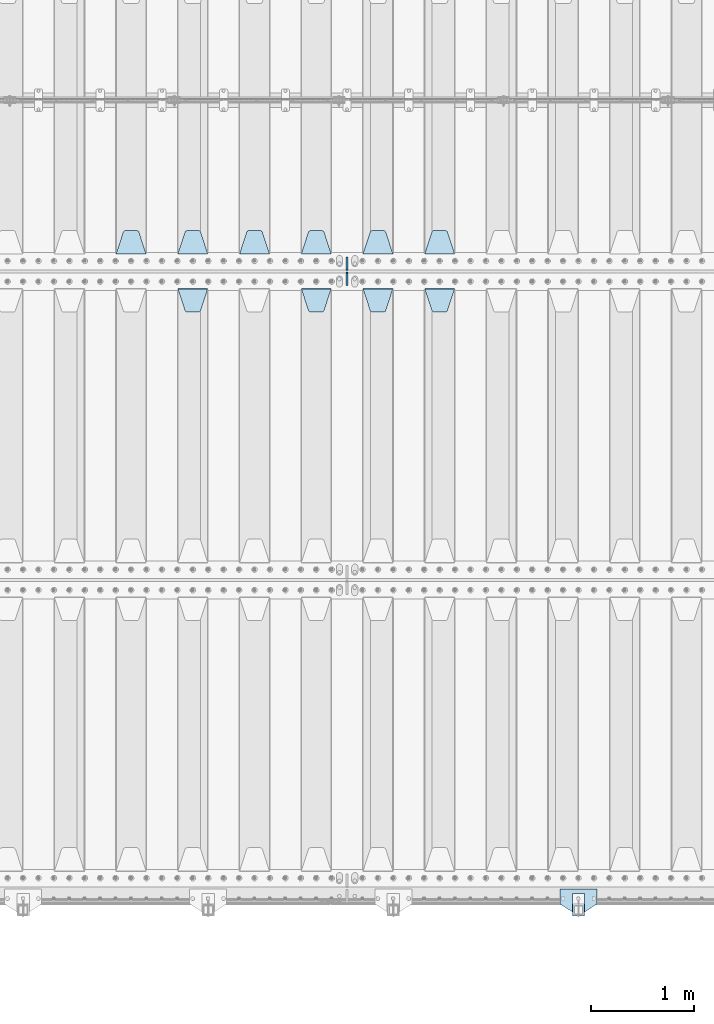
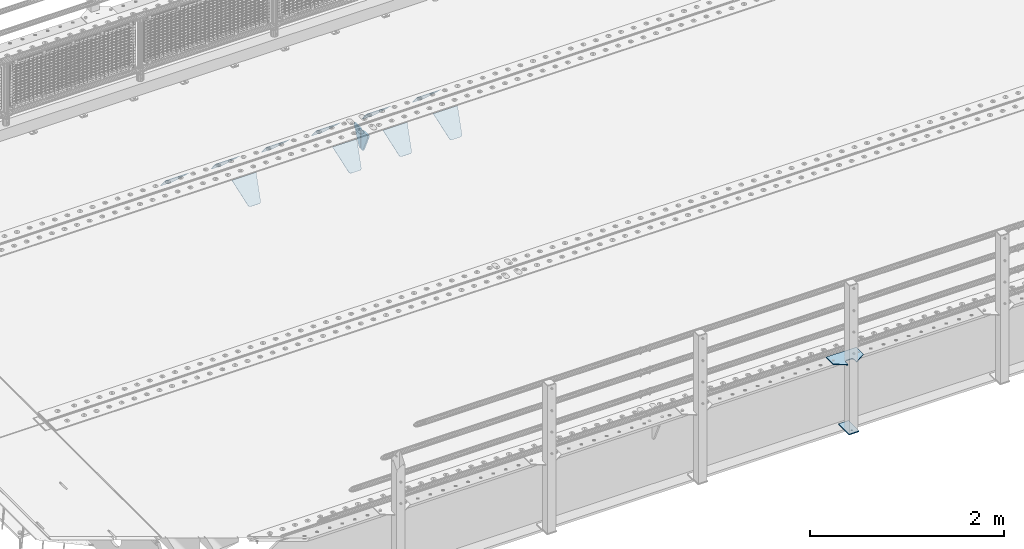
# One storey, part 202 of 247: 14 plates.
"""IFC2X3 building model written with IfcOpenShell, lengths in millimetres."""

from ifc_helpers import new_model, si_unit, frame, origin_with_axes, place, context, subcontext, project, spatial, faceted_brep, material, type_object, element, save


model = new_model("IFC2X3")

# Units and contexts
model_context = context("Model", 3, precision=1e-05, world=origin_with_axes())
body_context = subcontext(model_context, "Body", "Model", "MODEL_VIEW")
ifc_project = project(units=[si_unit("LENGTHUNIT", "METRE", prefix="MILLI"), si_unit("AREAUNIT", "SQUARE_METRE"), si_unit("VOLUMEUNIT", "CUBIC_METRE"), si_unit("MASSUNIT", "GRAM", prefix="KILO"), si_unit("TIMEUNIT", "SECOND"), si_unit("PLANEANGLEUNIT", "RADIAN"), si_unit("SOLIDANGLEUNIT", "STERADIAN"), si_unit("THERMODYNAMICTEMPERATUREUNIT", "DEGREE_CELSIUS"), si_unit("LUMINOUSINTENSITYUNIT", "LUMEN")], contexts=[model_context])

# Site, building, storey
site_placement = place(None, origin_with_axes())
site = spatial("IfcSite", under=ifc_project, at=site_placement, CompositionType="ELEMENT")
building_placement = place(site_placement, origin_with_axes())
building = spatial("IfcBuilding", under=site, at=building_placement, Name="Standard", CompositionType="ELEMENT")
storey_placement = place(building_placement, origin_with_axes())
storey = spatial("IfcBuildingStorey", under=building, at=storey_placement, Name="Undefined", CompositionType="ELEMENT", Elevation=0.0)

# Plates
ifc_material_1 = material(Name="STEEL/S355N")
plate_type_1 = type_object("IfcPlateType", PredefinedType="NOTDEFINED")
plate_1_placement = place(storey_placement, frame((6255.0, 5831.76776695594, -1.767766952965), z_axis=(0.0, -0.707106781186548, -0.707106781186547), x_axis=(1.0, 0.0, 0.0)))
element("IfcPlate", 1, at=plate_1_placement, inside=storey, type_object=plate_type_1, material=ifc_material_1, context=body_context, shape_type="Brep", body=[
    faceted_brep([(0.0, -2.49999999999909, 0.0), (69.345504679477, -2.5, 300.17173142483), (69.345504679477, 2.50000000000091, 300.171731424831), (0.0, 2.5, -9.09494701772928e-13), (70.9274061199576, -2.5, 304.897442415399), (70.9274061199576, 2.50000000000091, 304.8974424154), (73.3818627772307, -2.49999999999909, 309.234538108527), (73.3818627772307, 2.5, 309.234538108526), (76.6187032999551, -2.5, 313.023683126102), (76.6187032999551, 2.50000000000091, 313.023683126102), (80.5190132704993, -2.49999999999909, 316.125672595371), (80.5190132704993, 2.50000000000091, 316.125672595372), (84.9395038596849, -2.49999999999909, 318.426546230476), (84.9395038596849, 2.5, 318.426546230475), (89.7177759439219, -2.5, 319.841774983274), (89.7177759439219, 2.50000000000091, 319.841774983275), (94.678286292652, -2.5, 320.319366455077), (94.678286292652, 2.50000000000091, 320.319366455077), (195.321713707348, -2.5, 320.319366455077), (195.321713707348, 2.50000000000091, 320.319366455077), (200.282224056078, -2.5, 319.841774983274), (200.282224056078, 2.50000000000091, 319.841774983275), (205.060496140315, -2.5, 318.426546230475), (205.060496140315, 2.5, 318.426546230474), (209.480986729501, -2.49999999999818, 316.12567259537), (209.480986729501, 2.50000000000091, 316.12567259537), (213.381296700045, -2.5, 313.023683126101), (213.381296700045, 2.50000000000091, 313.023683126101), (216.618137222769, -2.5, 309.234538108525), (216.618137222769, 2.5, 309.234538108525), (219.072593880042, -2.49999999999909, 304.897442415398), (219.072593880042, 2.5, 304.897442415398), (220.654495320523, -2.5, 300.17173142483), (220.654495320523, 2.50000000000091, 300.171731424831), (290.0, -2.49999999999909, 0.0), (290.0, 2.5, -9.09494701772928e-13)], [[[0, 1, 2, 3]], [[1, 4, 5, 2]], [[4, 6, 7, 5]], [[6, 8, 9, 7]], [[8, 10, 11, 9]], [[10, 12, 13, 11]], [[12, 14, 15, 13]], [[14, 16, 17, 15]], [[16, 18, 19, 17]], [[18, 20, 21, 19]], [[20, 22, 23, 21]], [[22, 24, 25, 23]], [[24, 26, 27, 25]], [[26, 28, 29, 27]], [[28, 30, 31, 29]], [[30, 32, 33, 31]], [[32, 34, 35, 33]], [[34, 0, 3, 35]], [[5, 7, 9, 11, 13, 15, 17, 19, 21, 23, 25, 27, 29, 31, 33, 35, 3, 2]], [[34, 32, 30, 28, 26, 24, 22, 20, 18, 16, 14, 12, 10, 8, 6, 4, 1, 0]]]),
])
plate_2_placement = place(storey_placement, frame((5655.0, 5831.76776695594, -1.767766952965), z_axis=(0.0, -0.707106781186548, -0.707106781186547), x_axis=(1.0, 0.0, 0.0)))
element("IfcPlate", 2, at=plate_2_placement, inside=storey, type_object=plate_type_1, material=ifc_material_1, context=body_context, shape_type="Brep", body=[
    faceted_brep([(0.0, -2.49999999999909, 0.0), (69.345504679477, -2.5, 300.17173142483), (69.345504679477, 2.50000000000091, 300.171731424831), (0.0, 2.5, -9.09494701772928e-13), (70.9274061199576, -2.5, 304.897442415399), (70.9274061199576, 2.50000000000091, 304.8974424154), (73.3818627772307, -2.49999999999909, 309.234538108527), (73.3818627772307, 2.5, 309.234538108526), (76.6187032999551, -2.5, 313.023683126102), (76.6187032999551, 2.50000000000091, 313.023683126102), (80.5190132704993, -2.49999999999909, 316.125672595371), (80.5190132704993, 2.50000000000091, 316.125672595372), (84.9395038596849, -2.49999999999909, 318.426546230476), (84.9395038596849, 2.5, 318.426546230475), (89.7177759439219, -2.5, 319.841774983274), (89.7177759439219, 2.50000000000091, 319.841774983275), (94.678286292652, -2.5, 320.319366455077), (94.678286292652, 2.50000000000091, 320.319366455077), (195.321713707348, -2.5, 320.319366455077), (195.321713707348, 2.50000000000091, 320.319366455077), (200.282224056078, -2.5, 319.841774983274), (200.282224056078, 2.50000000000091, 319.841774983275), (205.060496140315, -2.5, 318.426546230475), (205.060496140315, 2.5, 318.426546230474), (209.480986729501, -2.49999999999818, 316.12567259537), (209.480986729501, 2.50000000000091, 316.12567259537), (213.381296700045, -2.5, 313.023683126101), (213.381296700045, 2.50000000000091, 313.023683126101), (216.618137222769, -2.5, 309.234538108525), (216.618137222769, 2.5, 309.234538108525), (219.072593880042, -2.49999999999909, 304.897442415398), (219.072593880042, 2.5, 304.897442415398), (220.654495320523, -2.5, 300.17173142483), (220.654495320523, 2.50000000000091, 300.171731424831), (290.0, -2.49999999999909, 0.0), (290.0, 2.5, -9.09494701772928e-13)], [[[0, 1, 2, 3]], [[1, 4, 5, 2]], [[4, 6, 7, 5]], [[6, 8, 9, 7]], [[8, 10, 11, 9]], [[10, 12, 13, 11]], [[12, 14, 15, 13]], [[14, 16, 17, 15]], [[16, 18, 19, 17]], [[18, 20, 21, 19]], [[20, 22, 23, 21]], [[22, 24, 25, 23]], [[24, 26, 27, 25]], [[26, 28, 29, 27]], [[28, 30, 31, 29]], [[30, 32, 33, 31]], [[32, 34, 35, 33]], [[34, 0, 3, 35]], [[5, 7, 9, 11, 13, 15, 17, 19, 21, 23, 25, 27, 29, 31, 33, 35, 3, 2]], [[34, 32, 30, 28, 26, 24, 22, 20, 18, 16, 14, 12, 10, 8, 6, 4, 1, 0]]]),
])
plate_3_placement = place(storey_placement, frame((5055.0, 5831.76776695594, -1.767766952965), z_axis=(0.0, -0.707106781186548, -0.707106781186547), x_axis=(1.0, 0.0, 0.0)))
element("IfcPlate", 3, at=plate_3_placement, inside=storey, type_object=plate_type_1, material=ifc_material_1, context=body_context, shape_type="Brep", body=[
    faceted_brep([(0.0, -2.49999999999909, 0.0), (69.345504679477, -2.5, 300.17173142483), (69.345504679477, 2.50000000000091, 300.171731424831), (0.0, 2.5, -9.09494701772928e-13), (70.9274061199576, -2.5, 304.897442415399), (70.9274061199576, 2.50000000000091, 304.8974424154), (73.3818627772307, -2.49999999999909, 309.234538108527), (73.3818627772307, 2.5, 309.234538108526), (76.6187032999551, -2.5, 313.023683126102), (76.6187032999551, 2.50000000000091, 313.023683126102), (80.5190132704993, -2.49999999999909, 316.125672595371), (80.5190132704993, 2.50000000000091, 316.125672595372), (84.9395038596849, -2.49999999999909, 318.426546230476), (84.9395038596849, 2.5, 318.426546230475), (89.7177759439219, -2.5, 319.841774983274), (89.7177759439219, 2.50000000000091, 319.841774983275), (94.678286292652, -2.5, 320.319366455077), (94.678286292652, 2.50000000000091, 320.319366455077), (195.321713707348, -2.5, 320.319366455077), (195.321713707348, 2.50000000000091, 320.319366455077), (200.282224056078, -2.5, 319.841774983274), (200.282224056078, 2.50000000000091, 319.841774983275), (205.060496140315, -2.5, 318.426546230475), (205.060496140315, 2.5, 318.426546230474), (209.480986729501, -2.49999999999818, 316.12567259537), (209.480986729501, 2.50000000000091, 316.12567259537), (213.381296700045, -2.5, 313.023683126101), (213.381296700045, 2.50000000000091, 313.023683126101), (216.618137222769, -2.5, 309.234538108525), (216.618137222769, 2.5, 309.234538108525), (219.072593880042, -2.49999999999909, 304.897442415398), (219.072593880042, 2.5, 304.897442415398), (220.654495320523, -2.5, 300.17173142483), (220.654495320523, 2.50000000000091, 300.171731424831), (290.0, -2.49999999999909, 0.0), (290.0, 2.5, -9.09494701772928e-13)], [[[0, 1, 2, 3]], [[1, 4, 5, 2]], [[4, 6, 7, 5]], [[6, 8, 9, 7]], [[8, 10, 11, 9]], [[10, 12, 13, 11]], [[12, 14, 15, 13]], [[14, 16, 17, 15]], [[16, 18, 19, 17]], [[18, 20, 21, 19]], [[20, 22, 23, 21]], [[22, 24, 25, 23]], [[24, 26, 27, 25]], [[26, 28, 29, 27]], [[28, 30, 31, 29]], [[30, 32, 33, 31]], [[32, 34, 35, 33]], [[34, 0, 3, 35]], [[5, 7, 9, 11, 13, 15, 17, 19, 21, 23, 25, 27, 29, 31, 33, 35, 3, 2]], [[34, 32, 30, 28, 26, 24, 22, 20, 18, 16, 14, 12, 10, 8, 6, 4, 1, 0]]]),
])
plate_4_placement = place(storey_placement, frame((3855.0, 5831.76776695594, -1.767766952965), z_axis=(0.0, -0.707106781186548, -0.707106781186547), x_axis=(1.0, 0.0, 0.0)))
element("IfcPlate", 4, at=plate_4_placement, inside=storey, type_object=plate_type_1, material=ifc_material_1, context=body_context, shape_type="Brep", body=[
    faceted_brep([(0.0, -2.49999999999909, 0.0), (69.345504679477, -2.5, 300.17173142483), (69.345504679477, 2.50000000000091, 300.171731424831), (0.0, 2.5, -9.09494701772928e-13), (70.9274061199576, -2.5, 304.897442415399), (70.9274061199576, 2.50000000000091, 304.8974424154), (73.3818627772307, -2.49999999999909, 309.234538108527), (73.3818627772307, 2.5, 309.234538108526), (76.6187032999551, -2.5, 313.023683126102), (76.6187032999551, 2.50000000000091, 313.023683126102), (80.5190132704993, -2.49999999999909, 316.125672595371), (80.5190132704993, 2.50000000000091, 316.125672595372), (84.9395038596849, -2.49999999999909, 318.426546230476), (84.9395038596849, 2.5, 318.426546230475), (89.7177759439219, -2.5, 319.841774983274), (89.7177759439219, 2.50000000000091, 319.841774983275), (94.678286292652, -2.5, 320.319366455077), (94.678286292652, 2.50000000000091, 320.319366455077), (195.321713707348, -2.5, 320.319366455077), (195.321713707348, 2.50000000000091, 320.319366455077), (200.282224056078, -2.5, 319.841774983274), (200.282224056078, 2.50000000000091, 319.841774983275), (205.060496140315, -2.5, 318.426546230475), (205.060496140315, 2.5, 318.426546230474), (209.480986729501, -2.49999999999818, 316.12567259537), (209.480986729501, 2.50000000000091, 316.12567259537), (213.381296700045, -2.5, 313.023683126101), (213.381296700045, 2.50000000000091, 313.023683126101), (216.618137222769, -2.5, 309.234538108525), (216.618137222769, 2.5, 309.234538108525), (219.072593880042, -2.49999999999909, 304.897442415398), (219.072593880042, 2.5, 304.897442415398), (220.654495320523, -2.5, 300.17173142483), (220.654495320523, 2.50000000000091, 300.171731424831), (290.0, -2.49999999999909, 0.0), (290.0, 2.5, -9.09494701772928e-13)], [[[0, 1, 2, 3]], [[1, 4, 5, 2]], [[4, 6, 7, 5]], [[6, 8, 9, 7]], [[8, 10, 11, 9]], [[10, 12, 13, 11]], [[12, 14, 15, 13]], [[14, 16, 17, 15]], [[16, 18, 19, 17]], [[18, 20, 21, 19]], [[20, 22, 23, 21]], [[22, 24, 25, 23]], [[24, 26, 27, 25]], [[26, 28, 29, 27]], [[28, 30, 31, 29]], [[30, 32, 33, 31]], [[32, 34, 35, 33]], [[34, 0, 3, 35]], [[5, 7, 9, 11, 13, 15, 17, 19, 21, 23, 25, 27, 29, 31, 33, 35, 3, 2]], [[34, 32, 30, 28, 26, 24, 22, 20, 18, 16, 14, 12, 10, 8, 6, 4, 1, 0]]]),
])
plate_5_placement = place(storey_placement, frame((6545.0, 6168.23223304703, -1.76776695296758), z_axis=(0.0, 0.707106781186548, -0.707106781186547), x_axis=(-1.0, 0.0, 0.0)))
element("IfcPlate", 5, at=plate_5_placement, inside=storey, type_object=plate_type_1, material=ifc_material_1, context=body_context, shape_type="Brep", body=[
    faceted_brep([(0.0, -2.49999999999909, 0.0), (69.345504679477, -2.5, 300.17173142483), (69.345504679477, 2.50000000000091, 300.171731424831), (0.0, 2.5, -9.09494701772928e-13), (70.9274061199576, -2.5, 304.897442415399), (70.9274061199576, 2.50000000000091, 304.8974424154), (73.3818627772307, -2.49999999999909, 309.234538108527), (73.3818627772307, 2.5, 309.234538108526), (76.6187032999551, -2.5, 313.023683126102), (76.6187032999551, 2.50000000000091, 313.023683126102), (80.5190132704993, -2.49999999999909, 316.125672595371), (80.5190132704993, 2.50000000000091, 316.125672595372), (84.9395038596849, -2.49999999999909, 318.426546230476), (84.9395038596849, 2.5, 318.426546230475), (89.7177759439219, -2.5, 319.841774983274), (89.7177759439219, 2.50000000000091, 319.841774983275), (94.678286292652, -2.5, 320.319366455077), (94.678286292652, 2.50000000000091, 320.319366455077), (195.321713707348, -2.5, 320.319366455077), (195.321713707348, 2.50000000000091, 320.319366455077), (200.282224056078, -2.5, 319.841774983274), (200.282224056078, 2.50000000000091, 319.841774983275), (205.060496140315, -2.5, 318.426546230475), (205.060496140315, 2.5, 318.426546230474), (209.480986729501, -2.49999999999818, 316.12567259537), (209.480986729501, 2.50000000000091, 316.12567259537), (213.381296700045, -2.5, 313.023683126101), (213.381296700045, 2.50000000000091, 313.023683126101), (216.618137222769, -2.5, 309.234538108525), (216.618137222769, 2.5, 309.234538108525), (219.072593880042, -2.49999999999909, 304.897442415398), (219.072593880042, 2.5, 304.897442415398), (220.654495320523, -2.5, 300.17173142483), (220.654495320523, 2.50000000000091, 300.171731424831), (290.0, -2.49999999999909, 0.0), (290.0, 2.5, -9.09494701772928e-13)], [[[0, 1, 2, 3]], [[1, 4, 5, 2]], [[4, 6, 7, 5]], [[6, 8, 9, 7]], [[8, 10, 11, 9]], [[10, 12, 13, 11]], [[12, 14, 15, 13]], [[14, 16, 17, 15]], [[16, 18, 19, 17]], [[18, 20, 21, 19]], [[20, 22, 23, 21]], [[22, 24, 25, 23]], [[24, 26, 27, 25]], [[26, 28, 29, 27]], [[28, 30, 31, 29]], [[30, 32, 33, 31]], [[32, 34, 35, 33]], [[34, 0, 3, 35]], [[5, 7, 9, 11, 13, 15, 17, 19, 21, 23, 25, 27, 29, 31, 33, 35, 3, 2]], [[34, 32, 30, 28, 26, 24, 22, 20, 18, 16, 14, 12, 10, 8, 6, 4, 1, 0]]]),
])
plate_6_placement = place(storey_placement, frame((5945.0, 6168.23223304703, -1.76776695296758), z_axis=(0.0, 0.707106781186548, -0.707106781186547), x_axis=(-1.0, 0.0, 0.0)))
element("IfcPlate", 6, at=plate_6_placement, inside=storey, type_object=plate_type_1, material=ifc_material_1, context=body_context, shape_type="Brep", body=[
    faceted_brep([(0.0, -2.49999999999909, 0.0), (69.345504679477, -2.5, 300.17173142483), (69.345504679477, 2.50000000000091, 300.171731424831), (0.0, 2.5, -9.09494701772928e-13), (70.9274061199576, -2.5, 304.897442415399), (70.9274061199576, 2.50000000000091, 304.8974424154), (73.3818627772307, -2.49999999999909, 309.234538108527), (73.3818627772307, 2.5, 309.234538108526), (76.6187032999551, -2.5, 313.023683126102), (76.6187032999551, 2.50000000000091, 313.023683126102), (80.5190132704993, -2.49999999999909, 316.125672595371), (80.5190132704993, 2.50000000000091, 316.125672595372), (84.9395038596849, -2.49999999999909, 318.426546230476), (84.9395038596849, 2.5, 318.426546230475), (89.7177759439219, -2.5, 319.841774983274), (89.7177759439219, 2.50000000000091, 319.841774983275), (94.678286292652, -2.5, 320.319366455077), (94.678286292652, 2.50000000000091, 320.319366455077), (195.321713707348, -2.5, 320.319366455077), (195.321713707348, 2.50000000000091, 320.319366455077), (200.282224056078, -2.5, 319.841774983274), (200.282224056078, 2.50000000000091, 319.841774983275), (205.060496140315, -2.5, 318.426546230475), (205.060496140315, 2.5, 318.426546230474), (209.480986729501, -2.49999999999818, 316.12567259537), (209.480986729501, 2.50000000000091, 316.12567259537), (213.381296700045, -2.5, 313.023683126101), (213.381296700045, 2.50000000000091, 313.023683126101), (216.618137222769, -2.5, 309.234538108525), (216.618137222769, 2.5, 309.234538108525), (219.072593880042, -2.49999999999909, 304.897442415398), (219.072593880042, 2.5, 304.897442415398), (220.654495320523, -2.5, 300.17173142483), (220.654495320523, 2.50000000000091, 300.171731424831), (290.0, -2.49999999999909, 0.0), (290.0, 2.5, -9.09494701772928e-13)], [[[0, 1, 2, 3]], [[1, 4, 5, 2]], [[4, 6, 7, 5]], [[6, 8, 9, 7]], [[8, 10, 11, 9]], [[10, 12, 13, 11]], [[12, 14, 15, 13]], [[14, 16, 17, 15]], [[16, 18, 19, 17]], [[18, 20, 21, 19]], [[20, 22, 23, 21]], [[22, 24, 25, 23]], [[24, 26, 27, 25]], [[26, 28, 29, 27]], [[28, 30, 31, 29]], [[30, 32, 33, 31]], [[32, 34, 35, 33]], [[34, 0, 3, 35]], [[5, 7, 9, 11, 13, 15, 17, 19, 21, 23, 25, 27, 29, 31, 33, 35, 3, 2]], [[34, 32, 30, 28, 26, 24, 22, 20, 18, 16, 14, 12, 10, 8, 6, 4, 1, 0]]]),
])
plate_7_placement = place(storey_placement, frame((5345.0, 6168.23223304703, -1.76776695296758), z_axis=(0.0, 0.707106781186548, -0.707106781186547), x_axis=(-1.0, 0.0, 0.0)))
element("IfcPlate", 7, at=plate_7_placement, inside=storey, type_object=plate_type_1, material=ifc_material_1, context=body_context, shape_type="Brep", body=[
    faceted_brep([(0.0, -2.49999999999909, 0.0), (69.345504679477, -2.5, 300.17173142483), (69.345504679477, 2.50000000000091, 300.171731424831), (0.0, 2.5, -9.09494701772928e-13), (70.9274061199576, -2.5, 304.897442415399), (70.9274061199576, 2.50000000000091, 304.8974424154), (73.3818627772307, -2.49999999999909, 309.234538108527), (73.3818627772307, 2.5, 309.234538108526), (76.6187032999551, -2.5, 313.023683126102), (76.6187032999551, 2.50000000000091, 313.023683126102), (80.5190132704993, -2.49999999999909, 316.125672595371), (80.5190132704993, 2.50000000000091, 316.125672595372), (84.9395038596849, -2.49999999999909, 318.426546230476), (84.9395038596849, 2.5, 318.426546230475), (89.7177759439219, -2.5, 319.841774983274), (89.7177759439219, 2.50000000000091, 319.841774983275), (94.678286292652, -2.5, 320.319366455077), (94.678286292652, 2.50000000000091, 320.319366455077), (195.321713707348, -2.5, 320.319366455077), (195.321713707348, 2.50000000000091, 320.319366455077), (200.282224056078, -2.5, 319.841774983274), (200.282224056078, 2.50000000000091, 319.841774983275), (205.060496140315, -2.5, 318.426546230475), (205.060496140315, 2.5, 318.426546230474), (209.480986729501, -2.49999999999818, 316.12567259537), (209.480986729501, 2.50000000000091, 316.12567259537), (213.381296700045, -2.5, 313.023683126101), (213.381296700045, 2.50000000000091, 313.023683126101), (216.618137222769, -2.5, 309.234538108525), (216.618137222769, 2.5, 309.234538108525), (219.072593880042, -2.49999999999909, 304.897442415398), (219.072593880042, 2.5, 304.897442415398), (220.654495320523, -2.5, 300.17173142483), (220.654495320523, 2.50000000000091, 300.171731424831), (290.0, -2.49999999999909, 0.0), (290.0, 2.5, -9.09494701772928e-13)], [[[0, 1, 2, 3]], [[1, 4, 5, 2]], [[4, 6, 7, 5]], [[6, 8, 9, 7]], [[8, 10, 11, 9]], [[10, 12, 13, 11]], [[12, 14, 15, 13]], [[14, 16, 17, 15]], [[16, 18, 19, 17]], [[18, 20, 21, 19]], [[20, 22, 23, 21]], [[22, 24, 25, 23]], [[24, 26, 27, 25]], [[26, 28, 29, 27]], [[28, 30, 31, 29]], [[30, 32, 33, 31]], [[32, 34, 35, 33]], [[34, 0, 3, 35]], [[5, 7, 9, 11, 13, 15, 17, 19, 21, 23, 25, 27, 29, 31, 33, 35, 3, 2]], [[34, 32, 30, 28, 26, 24, 22, 20, 18, 16, 14, 12, 10, 8, 6, 4, 1, 0]]]),
])
plate_8_placement = place(storey_placement, frame((4745.0, 6168.23223304703, -1.76776695296758), z_axis=(0.0, 0.707106781186548, -0.707106781186547), x_axis=(-1.0, 0.0, 0.0)))
element("IfcPlate", 8, at=plate_8_placement, inside=storey, type_object=plate_type_1, material=ifc_material_1, context=body_context, shape_type="Brep", body=[
    faceted_brep([(0.0, -2.49999999999909, 0.0), (69.345504679477, -2.5, 300.17173142483), (69.345504679477, 2.50000000000091, 300.171731424831), (0.0, 2.5, -9.09494701772928e-13), (70.9274061199576, -2.5, 304.897442415399), (70.9274061199576, 2.50000000000091, 304.8974424154), (73.3818627772307, -2.49999999999909, 309.234538108527), (73.3818627772307, 2.5, 309.234538108526), (76.6187032999551, -2.5, 313.023683126102), (76.6187032999551, 2.50000000000091, 313.023683126102), (80.5190132704993, -2.49999999999909, 316.125672595371), (80.5190132704993, 2.50000000000091, 316.125672595372), (84.9395038596849, -2.49999999999909, 318.426546230476), (84.9395038596849, 2.5, 318.426546230475), (89.7177759439219, -2.5, 319.841774983274), (89.7177759439219, 2.50000000000091, 319.841774983275), (94.678286292652, -2.5, 320.319366455077), (94.678286292652, 2.50000000000091, 320.319366455077), (195.321713707348, -2.5, 320.319366455077), (195.321713707348, 2.50000000000091, 320.319366455077), (200.282224056078, -2.5, 319.841774983274), (200.282224056078, 2.50000000000091, 319.841774983275), (205.060496140315, -2.5, 318.426546230475), (205.060496140315, 2.5, 318.426546230474), (209.480986729501, -2.49999999999818, 316.12567259537), (209.480986729501, 2.50000000000091, 316.12567259537), (213.381296700045, -2.5, 313.023683126101), (213.381296700045, 2.50000000000091, 313.023683126101), (216.618137222769, -2.5, 309.234538108525), (216.618137222769, 2.5, 309.234538108525), (219.072593880042, -2.49999999999909, 304.897442415398), (219.072593880042, 2.5, 304.897442415398), (220.654495320523, -2.5, 300.17173142483), (220.654495320523, 2.50000000000091, 300.171731424831), (290.0, -2.49999999999909, 0.0), (290.0, 2.5, -9.09494701772928e-13)], [[[0, 1, 2, 3]], [[1, 4, 5, 2]], [[4, 6, 7, 5]], [[6, 8, 9, 7]], [[8, 10, 11, 9]], [[10, 12, 13, 11]], [[12, 14, 15, 13]], [[14, 16, 17, 15]], [[16, 18, 19, 17]], [[18, 20, 21, 19]], [[20, 22, 23, 21]], [[22, 24, 25, 23]], [[24, 26, 27, 25]], [[26, 28, 29, 27]], [[28, 30, 31, 29]], [[30, 32, 33, 31]], [[32, 34, 35, 33]], [[34, 0, 3, 35]], [[5, 7, 9, 11, 13, 15, 17, 19, 21, 23, 25, 27, 29, 31, 33, 35, 3, 2]], [[34, 32, 30, 28, 26, 24, 22, 20, 18, 16, 14, 12, 10, 8, 6, 4, 1, 0]]]),
])
plate_9_placement = place(storey_placement, frame((4145.0, 6168.23223304703, -1.76776695296758), z_axis=(0.0, 0.707106781186548, -0.707106781186547), x_axis=(-1.0, 0.0, 0.0)))
element("IfcPlate", 9, at=plate_9_placement, inside=storey, type_object=plate_type_1, material=ifc_material_1, context=body_context, shape_type="Brep", body=[
    faceted_brep([(0.0, -2.49999999999909, 0.0), (69.345504679477, -2.5, 300.17173142483), (69.345504679477, 2.50000000000091, 300.171731424831), (0.0, 2.5, -9.09494701772928e-13), (70.9274061199576, -2.5, 304.897442415399), (70.9274061199576, 2.50000000000091, 304.8974424154), (73.3818627772307, -2.49999999999909, 309.234538108527), (73.3818627772307, 2.5, 309.234538108526), (76.6187032999551, -2.5, 313.023683126102), (76.6187032999551, 2.50000000000091, 313.023683126102), (80.5190132704993, -2.49999999999909, 316.125672595371), (80.5190132704993, 2.50000000000091, 316.125672595372), (84.9395038596849, -2.49999999999909, 318.426546230476), (84.9395038596849, 2.5, 318.426546230475), (89.7177759439219, -2.5, 319.841774983274), (89.7177759439219, 2.50000000000091, 319.841774983275), (94.678286292652, -2.5, 320.319366455077), (94.678286292652, 2.50000000000091, 320.319366455077), (195.321713707348, -2.5, 320.319366455077), (195.321713707348, 2.50000000000091, 320.319366455077), (200.282224056078, -2.5, 319.841774983274), (200.282224056078, 2.50000000000091, 319.841774983275), (205.060496140315, -2.5, 318.426546230475), (205.060496140315, 2.5, 318.426546230474), (209.480986729501, -2.49999999999818, 316.12567259537), (209.480986729501, 2.50000000000091, 316.12567259537), (213.381296700045, -2.5, 313.023683126101), (213.381296700045, 2.50000000000091, 313.023683126101), (216.618137222769, -2.5, 309.234538108525), (216.618137222769, 2.5, 309.234538108525), (219.072593880042, -2.49999999999909, 304.897442415398), (219.072593880042, 2.5, 304.897442415398), (220.654495320523, -2.5, 300.17173142483), (220.654495320523, 2.50000000000091, 300.171731424831), (290.0, -2.49999999999909, 0.0), (290.0, 2.5, -9.09494701772928e-13)], [[[0, 1, 2, 3]], [[1, 4, 5, 2]], [[4, 6, 7, 5]], [[6, 8, 9, 7]], [[8, 10, 11, 9]], [[10, 12, 13, 11]], [[12, 14, 15, 13]], [[14, 16, 17, 15]], [[16, 18, 19, 17]], [[18, 20, 21, 19]], [[20, 22, 23, 21]], [[22, 24, 25, 23]], [[24, 26, 27, 25]], [[26, 28, 29, 27]], [[28, 30, 31, 29]], [[30, 32, 33, 31]], [[32, 34, 35, 33]], [[34, 0, 3, 35]], [[5, 7, 9, 11, 13, 15, 17, 19, 21, 23, 25, 27, 29, 31, 33, 35, 3, 2]], [[34, 32, 30, 28, 26, 24, 22, 20, 18, 16, 14, 12, 10, 8, 6, 4, 1, 0]]]),
])
plate_10_placement = place(storey_placement, frame((3545.0, 6168.23223304703, -1.76776695296758), z_axis=(0.0, 0.707106781186548, -0.707106781186547), x_axis=(-1.0, 0.0, 0.0)))
element("IfcPlate", 10, at=plate_10_placement, inside=storey, type_object=plate_type_1, material=ifc_material_1, context=body_context, shape_type="Brep", body=[
    faceted_brep([(0.0, -2.49999999999909, 0.0), (69.345504679477, -2.5, 300.17173142483), (69.345504679477, 2.50000000000091, 300.171731424831), (0.0, 2.5, -9.09494701772928e-13), (70.9274061199576, -2.5, 304.897442415399), (70.9274061199576, 2.50000000000091, 304.8974424154), (73.3818627772307, -2.49999999999909, 309.234538108527), (73.3818627772307, 2.5, 309.234538108526), (76.6187032999551, -2.5, 313.023683126102), (76.6187032999551, 2.50000000000091, 313.023683126102), (80.5190132704993, -2.49999999999909, 316.125672595371), (80.5190132704993, 2.50000000000091, 316.125672595372), (84.9395038596849, -2.49999999999909, 318.426546230476), (84.9395038596849, 2.5, 318.426546230475), (89.7177759439219, -2.5, 319.841774983274), (89.7177759439219, 2.50000000000091, 319.841774983275), (94.678286292652, -2.5, 320.319366455077), (94.678286292652, 2.50000000000091, 320.319366455077), (195.321713707348, -2.5, 320.319366455077), (195.321713707348, 2.50000000000091, 320.319366455077), (200.282224056078, -2.5, 319.841774983274), (200.282224056078, 2.50000000000091, 319.841774983275), (205.060496140315, -2.5, 318.426546230475), (205.060496140315, 2.5, 318.426546230474), (209.480986729501, -2.49999999999818, 316.12567259537), (209.480986729501, 2.50000000000091, 316.12567259537), (213.381296700045, -2.5, 313.023683126101), (213.381296700045, 2.50000000000091, 313.023683126101), (216.618137222769, -2.5, 309.234538108525), (216.618137222769, 2.5, 309.234538108525), (219.072593880042, -2.49999999999909, 304.897442415398), (219.072593880042, 2.5, 304.897442415398), (220.654495320523, -2.5, 300.17173142483), (220.654495320523, 2.50000000000091, 300.171731424831), (290.0, -2.49999999999909, 0.0), (290.0, 2.5, -9.09494701772928e-13)], [[[0, 1, 2, 3]], [[1, 4, 5, 2]], [[4, 6, 7, 5]], [[6, 8, 9, 7]], [[8, 10, 11, 9]], [[10, 12, 13, 11]], [[12, 14, 15, 13]], [[14, 16, 17, 15]], [[16, 18, 19, 17]], [[18, 20, 21, 19]], [[20, 22, 23, 21]], [[22, 24, 25, 23]], [[24, 26, 27, 25]], [[26, 28, 29, 27]], [[28, 30, 31, 29]], [[30, 32, 33, 31]], [[32, 34, 35, 33]], [[34, 0, 3, 35]], [[5, 7, 9, 11, 13, 15, 17, 19, 21, 23, 25, 27, 29, 31, 33, 35, 3, 2]], [[34, 32, 30, 28, 26, 24, 22, 20, 18, 16, 14, 12, 10, 8, 6, 4, 1, 0]]]),
])
plate_type_2 = type_object("IfcPlateType", PredefinedType="NOTDEFINED")
for number, where, z_axis, x_axis in (
    (11, (5500.0, 6140.0, -30.0), (0.0, 0.0, -1.0), (0.0, -0.999999999999548, -9.5100000000016e-07)),
    (12, (5500.0, 5860.0, -30.0), (0.0, 0.0, -1.0), (0.0, 1.0, 0.0)),
):
    element("IfcPlate", number, at=place(storey_placement, frame(where, z_axis=z_axis, x_axis=x_axis)), inside=storey, type_object=plate_type_2, material=ifc_material_1, context=body_context, shape_type="Brep", body=[
        faceted_brep([(-5.6843418860808e-14, -9.99999999999989, 3.5527136788005e-15), (0.0, -10.0, 30.0), (0.0, 10.0, 30.0), (-5.6843418860808e-14, 10.0000000000001, 3.5527136788005e-15), (102.0, -10.0, 250.0), (102.0, 10.0, 250.0), (132.0, -10.0, 250.0), (132.0, 10.0, 250.0), (132.0, -10.0, 30.0), (132.0, 10.0, 30.0), (131.544232590366, -10.0, 24.790554669992), (131.544232590366, 10.0, 24.790554669992), (130.190778623577, -10.0, 19.7393957002299), (130.190778623577, 10.0, 19.7393957002299), (127.980762113533, -10.0, 15.0), (127.980762113533, 10.0, 15.0), (124.981333293569, -10.0, 10.7163717094038), (124.981333293569, 10.0, 10.7163717094038), (121.283628290596, -10.0, 7.01866670643062), (121.283628290596, 10.0, 7.01866670643062), (117.0, -10.0, 4.01923788646684), (117.0, 10.0, 4.01923788646684), (112.26060429977, -10.0, 1.80922137642278), (112.26060429977, 10.0, 1.80922137642278), (107.209445330008, -10.0, 0.455767409633722), (107.209445330008, 10.0, 0.455767409633722), (102.0, -10.0, 0.0), (102.0, 10.0, 0.0)], [[[0, 1, 2, 3]], [[1, 4, 5, 2]], [[4, 6, 7, 5]], [[6, 8, 9, 7]], [[8, 10, 11, 9]], [[10, 12, 13, 11]], [[12, 14, 15, 13]], [[14, 16, 17, 15]], [[16, 18, 19, 17]], [[18, 20, 21, 19]], [[20, 22, 23, 21]], [[22, 24, 25, 23]], [[24, 26, 27, 25]], [[26, 0, 3, 27]], [[5, 7, 9, 11, 13, 15, 17, 19, 21, 23, 25, 27, 3, 2]], [[26, 24, 22, 20, 18, 16, 14, 12, 10, 8, 6, 4, 1, 0]]]),
    ])
ifc_material_2 = material(Name="STEEL/S355J2")
plate_type_3 = type_object("IfcPlateType", PredefinedType="NOTDEFINED")
plate_11_placement = place(storey_placement, frame((7930.0, -4.99999999999636, 5.00000000004911), z_axis=(0.0, -0.999999999999548, -9.5100000000016e-07), x_axis=(-1.0, 0.0, 0.0)))
element("IfcPlate", 13, at=plate_11_placement, inside=storey, type_object=plate_type_3, material=ifc_material_2, context=body_context, shape_type="Brep", body=[
    faceted_brep([(9.04219632502645e-09, -5.00000000143385, -2.89173840428703e-09), (2.31396552408114e-06, -5.0, 145.0), (2.31396552408114e-06, 5.0, 145.0), (7.66340235713869e-09, 4.99999999856618, -2.89173840428703e-09), (130.0, -5.0, 230.0), (130.0, 5.0, 230.0), (130.0, -5.0, 180.0), (130.0, 5.0, 180.0), (130.48036798992, -5.0, 175.122741949597), (130.48036798992, 5.0, 175.122741949597), (131.903011687218, -5.0, 170.432914190873), (131.903011687218, 5.0, 170.432914190873), (134.213259692437, -5.0, 166.11074417451), (134.213259692437, 5.0, 166.11074417451), (137.322330470337, -5.0, 162.322330470337), (137.322330470337, 5.0, 162.322330470337), (141.11074417451, -5.0, 159.213259692437), (141.11074417451, 5.0, 159.213259692437), (145.432914190873, -5.0, 156.903011687218), (145.432914190873, 5.0, 156.903011687218), (150.122741949597, -5.0, 155.48036798992), (150.122741949597, 5.0, 155.48036798992), (155.0, -5.0, 155.0), (155.0, 5.0, 155.0), (205.0, -5.0, 155.0), (205.0, 5.0, 155.0), (209.877258050403, -5.0, 155.48036798992), (209.877258050403, 5.0, 155.48036798992), (214.567085809127, -5.0, 156.903011687218), (214.567085809127, 5.0, 156.903011687218), (218.88925582549, -5.0, 159.213259692437), (218.88925582549, 5.0, 159.213259692437), (222.677669529663, -5.0, 162.322330470337), (222.677669529663, 5.0, 162.322330470337), (225.786740307563, -5.0, 166.11074417451), (225.786740307563, 5.0, 166.11074417451), (228.096988312782, -5.0, 170.432914190873), (228.096988312782, 5.0, 170.432914190873), (229.51963201008, -5.0, 175.122741949597), (229.51963201008, 5.0, 175.122741949597), (230.0, -5.0, 180.0), (230.0, 5.0, 180.0), (230.0, -5.0, 230.0), (230.0, 5.0, 230.0), (360.0, -5.0, 145.0), (360.0, 5.0, 145.0), (360.0, -5.0, -7.27595761418343e-12), (360.0, 5.0, -7.27595761418343e-12)], [[[0, 1, 2, 3]], [[1, 4, 5, 2]], [[4, 6, 7, 5]], [[6, 8, 9, 7]], [[8, 10, 11, 9]], [[10, 12, 13, 11]], [[12, 14, 15, 13]], [[14, 16, 17, 15]], [[16, 18, 19, 17]], [[18, 20, 21, 19]], [[20, 22, 23, 21]], [[22, 24, 25, 23]], [[24, 26, 27, 25]], [[26, 28, 29, 27]], [[28, 30, 31, 29]], [[30, 32, 33, 31]], [[32, 34, 35, 33]], [[34, 36, 37, 35]], [[36, 38, 39, 37]], [[38, 40, 41, 39]], [[40, 42, 43, 41]], [[42, 44, 45, 43]], [[44, 46, 47, 45]], [[46, 0, 3, 47]], [[5, 7, 9, 11, 13, 15, 17, 19, 21, 23, 25, 27, 29, 31, 33, 35, 37, 39, 41, 43, 45, 47, 3, 2]], [[46, 44, 42, 40, 38, 36, 34, 32, 30, 28, 26, 24, 22, 20, 18, 16, 14, 12, 10, 8, 6, 4, 1, 0]]]),
])
plate_type_4 = type_object("IfcPlateType", PredefinedType="NOTDEFINED")
plate_12_placement = place(storey_placement, frame((7809.99999999986, -50.0000000002074, -850.000000000002), z_axis=(0.0, -0.999999999999548, -9.5100000000016e-07), x_axis=(-1.0, 0.0, 0.0)))
element("IfcPlate", 14, at=plate_12_placement, inside=storey, type_object=plate_type_4, material=ifc_material_2, context=body_context, shape_type="Brep", body=[
    faceted_brep([(53.6360389691836, -5.0, 176.363961030469), (53.6360389691836, 5.0, 176.363961030469), (59.9999999998618, 5.0, 178.999999999791), (59.9999999998618, -5.0, 178.999999999791), (66.3639610305399, 5.0, 176.363961030469), (66.3639610305399, -5.0, 176.363961030469), (68.9999999998618, 5.0, 169.999999999791), (68.9999999998618, -5.0, 169.999999999791), (66.3639610305399, 5.0, 163.636038969113), (66.3639610305399, -5.0, 163.636038969113), (59.9999999998618, 5.0, 160.999999999791), (59.9999999998618, -5.0, 160.999999999791), (53.6360389691836, 5.0, 163.636038969113), (53.6360389691836, -5.0, 163.636038969113), (50.9999999998618, 5.0, 169.999999999791), (50.9999999998618, -5.0, 169.999999999791), (120.0, -5.0, 0.0), (120.0, -5.0, 220.0), (0.0, -5.0, 220.0), (9.04219632502645e-09, -5.00000000143385, -2.89173840428703e-09), (7.66340235713869e-09, 4.99999999856618, -2.89173840428703e-09), (120.0, 5.0, 0.0), (120.0, 5.0, 220.0), (0.0, 5.0, 220.0)], [[[0, 1, 2, 3]], [[3, 2, 4, 5]], [[5, 4, 6, 7]], [[7, 6, 8, 9]], [[9, 8, 10, 11]], [[11, 10, 12, 13]], [[13, 12, 14, 15]], [[15, 14, 1, 0]], [[16, 17, 18, 19], [11, 13, 15, 0, 3, 5, 7, 9]], [[16, 19, 20, 21]], [[17, 16, 21, 22]], [[18, 17, 22, 23]], [[19, 18, 23, 20]], [[22, 21, 20, 23], [2, 1, 14, 12, 10, 8, 6, 4]]]),
])

save(model, "model.ifc")
